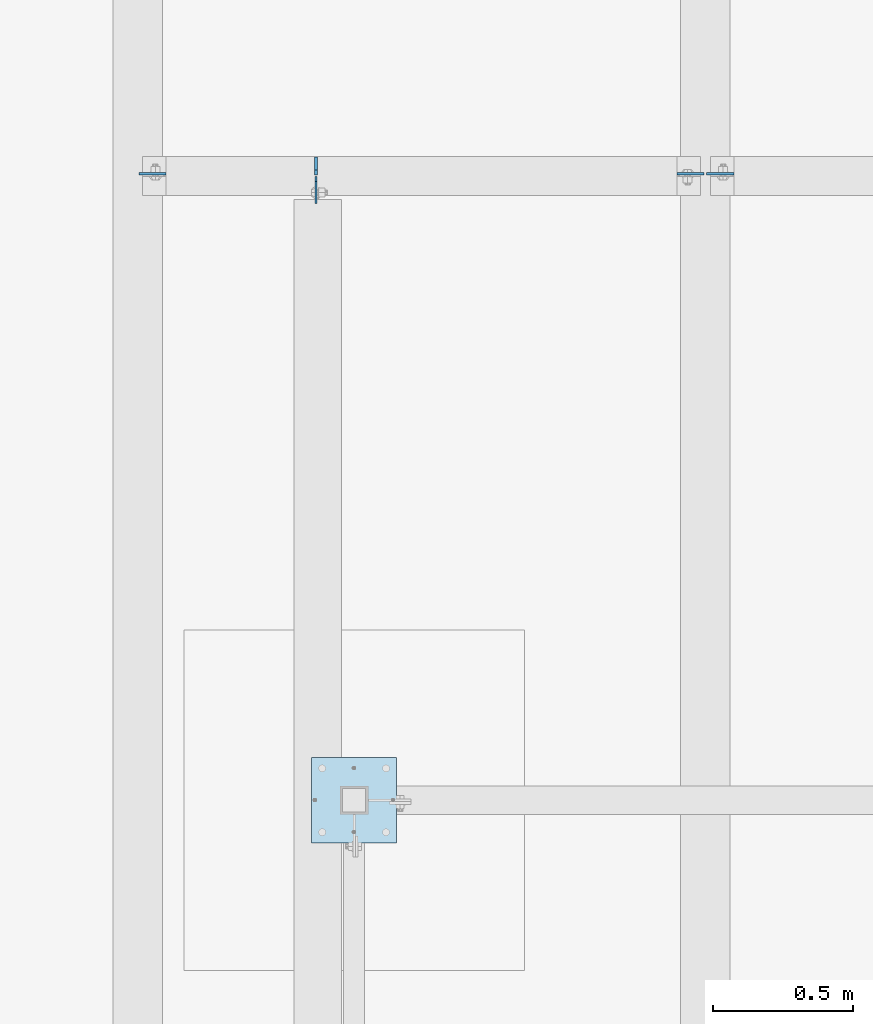
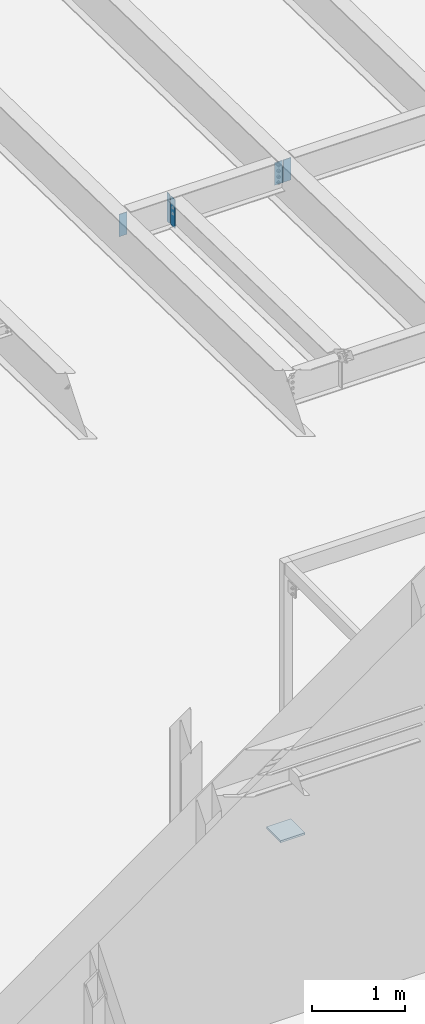
# One storey, part 1471 of 1763: 6 plates, 4 elements without a shape of their own.
"""IFC2X3 building model written with IfcOpenShell, lengths in millimetres."""

from ifc_helpers import new_model, si_unit, frame, origin_with_axes, place, context, subcontext, project, spatial, faceted_brep, material, type_object, element, aggregate, save


model = new_model("IFC2X3")

# Units and contexts
model_context = context("Model", 3, precision=1e-05, world=origin_with_axes())
body_context = subcontext(model_context, "Body", "Model", "MODEL_VIEW")
ifc_project = project(units=[si_unit("LENGTHUNIT", "METRE", prefix="MILLI"), si_unit("AREAUNIT", "SQUARE_METRE"), si_unit("VOLUMEUNIT", "CUBIC_METRE"), si_unit("MASSUNIT", "GRAM", prefix="KILO"), si_unit("TIMEUNIT", "SECOND"), si_unit("PLANEANGLEUNIT", "RADIAN"), si_unit("SOLIDANGLEUNIT", "STERADIAN"), si_unit("THERMODYNAMICTEMPERATUREUNIT", "DEGREE_CELSIUS"), si_unit("LUMINOUSINTENSITYUNIT", "LUMEN")], contexts=[model_context])

# Site, building, storey
site_placement = place(None, origin_with_axes())
site = spatial("IfcSite", under=ifc_project, at=site_placement, CompositionType="ELEMENT")
building_placement = place(site_placement, origin_with_axes())
building = spatial("IfcBuilding", under=site, at=building_placement, Name="Undefined", CompositionType="ELEMENT")
storey_placement = place(building_placement, origin_with_axes())
storey = spatial("IfcBuildingStorey", under=building, at=storey_placement, Name="Undefined", CompositionType="ELEMENT", Elevation=0.0)

# Assembly, plate
assembly_1_placement = place(storey_placement, origin_with_axes())
assembly_1 = element("IfcElementAssembly", 1, at=assembly_1_placement, inside=storey, Name="BEAM", AssemblyPlace="NOTDEFINED", PredefinedType="RIGID_FRAME")
ifc_material = material(Name="STEEL/A36")
plate_type_1 = type_object("IfcPlateType", PredefinedType="NOTDEFINED")
plate_1_placement = place(assembly_1_placement, frame((-58924.2622752818, -8766.2304259654, 11710.6291231283), z_axis=(0.0, 0.0, 1.0), x_axis=(0.0, -1.0, 0.0)))
plate_1 = element("IfcPlate", 2, at=plate_1_placement, type_object=plate_type_1, material=ifc_material, Name="PLATE", context=body_context, shape_type="Brep", body=[
    faceted_brep([(0.0, -3.17500000000291, 17.4624996185303), (0.0, -3.17500000000291, 363.53750038147), (0.0, 3.17500000000291, 363.53750038147), (0.0, 3.17500000000291, 17.4624996185303), (17.4624996185303, -3.17500000000291, 381.0), (17.4624996185303, 3.17500000000291, 381.0), (95.25, -3.17500000000291, 381.0), (95.25, 3.17500000000291, 381.0), (95.25, -3.17500000000291, 0.0), (95.25, 3.17500000000291, 0.0), (17.4624996185303, -3.17500000000291, 0.0), (17.4624996185303, 3.17500000000291, 0.0)], [[[0, 1, 2, 3]], [[1, 4, 5, 2]], [[4, 6, 7, 5]], [[6, 8, 9, 7]], [[8, 10, 11, 9]], [[10, 0, 3, 11]], [[5, 7, 9, 11, 3, 2]], [[10, 8, 6, 4, 1, 0]]]),
])

assembly_2_placement = place(storey_placement, origin_with_axes())
assembly_2 = element("IfcElementAssembly", 3, at=assembly_2_placement, inside=storey, Name="BEAM", AssemblyPlace="NOTDEFINED", PredefinedType="RIGID_FRAME")
plate_type_2 = type_object("IfcPlateType", PredefinedType="NOTDEFINED")
plate_2_placement = place(assembly_2_placement, frame((-57535.1997736983, -8755.91142595737, 12056.7041231251), z_axis=(-1.0, 0.0, 0.0), x_axis=(0.0, 0.0, -1.0)))
plate_2 = element("IfcPlate", 4, at=plate_2_placement, type_object=plate_type_2, material=ifc_material, Name="PLATE", context=body_context, shape_type="Brep", body=[
    faceted_brep([(0.0, -3.96900000000096, 0.0), (0.0, -3.96899999999914, 96.8375015258789), (0.0, 3.96899999999914, 96.8375015258789), (0.0, 3.96900000000096, 0.0), (292.100006103516, -3.96899999999914, 96.8375015258789), (292.100006103516, 3.96899999999914, 96.8375015258789), (292.100006103516, -3.96899999999914, 0.0), (292.100006103516, 3.96899999999914, 0.0)], [[[0, 1, 2, 3]], [[1, 4, 5, 2]], [[4, 6, 7, 5]], [[6, 0, 3, 7]], [[5, 7, 3, 2]], [[6, 4, 1, 0]]]),
])

assembly_3_placement = place(storey_placement, origin_with_axes())
assembly_3 = element("IfcElementAssembly", 5, at=assembly_3_placement, inside=storey, Name="BEAM", AssemblyPlace="NOTDEFINED", PredefinedType="RIGID_FRAME")
plate_3_placement = place(assembly_3_placement, frame((-59557.6747736983, -8755.91142595737, 12056.7041231251), z_axis=(1.0, 0.0, 0.0), x_axis=(0.0, 0.0, -1.0)))
plate_3 = element("IfcPlate", 6, at=plate_3_placement, type_object=plate_type_2, material=ifc_material, Name="PLATE", context=body_context, shape_type="Brep", body=[
    faceted_brep([(0.0, -3.96900000000096, 0.0), (0.0, -3.96899999999914, 96.8375015258789), (0.0, 3.96899999999914, 96.8375015258789), (0.0, 3.96900000000096, 0.0), (292.100006103516, -3.96899999999914, 96.8375015258789), (292.100006103516, 3.96899999999914, 96.8375015258789), (292.100006103516, -3.96899999999914, 0.0), (292.100006103516, 3.96899999999914, 0.0)], [[[0, 1, 2, 3]], [[1, 4, 5, 2]], [[4, 6, 7, 5]], [[6, 0, 3, 7]], [[5, 7, 3, 2]], [[6, 4, 1, 0]]]),
])
aggregate(assembly_3, [plate_3])

# Plate
plate_4_placement = place(assembly_2_placement, frame((-57525.6747736983, -8755.91142595737, 12056.7041231251), z_axis=(1.0, 0.0, 0.0), x_axis=(0.0, 0.0, -1.0)))
plate_4 = element("IfcPlate", 7, at=plate_4_placement, type_object=plate_type_2, material=ifc_material, Name="PLATE", context=body_context, shape_type="Brep", body=[
    faceted_brep([(0.0, -3.96900000000096, 0.0), (0.0, -3.96899999999914, 96.8375015258789), (0.0, 3.96899999999914, 96.8375015258789), (0.0, 3.96900000000096, 0.0), (292.100006103516, -3.96899999999914, 96.8375015258789), (292.100006103516, 3.96899999999914, 96.8375015258789), (292.100006103516, -3.96899999999914, 0.0), (292.100006103516, 3.96899999999914, 0.0)], [[[0, 1, 2, 3]], [[1, 4, 5, 2]], [[4, 6, 7, 5]], [[6, 0, 3, 7]], [[5, 7, 3, 2]], [[6, 4, 1, 0]]]),
])

aggregate(assembly_2, [plate_2, plate_4])

plate_type_3 = type_object("IfcPlateType", PredefinedType="NOTDEFINED")
plate_5_placement = place(assembly_1_placement, frame((-58924.2627751502, -8759.88042596541, 11710.6291231283), z_axis=(0.0, 0.0, 1.0), x_axis=(0.0, 1.0, 0.0)))
plate_5 = element("IfcPlate", 8, at=plate_5_placement, type_object=plate_type_3, material=ifc_material, Name="PLATE", context=body_context, shape_type="Brep", body=[
    faceted_brep([(0.0, -4.76249999999709, 17.4624996185303), (0.0, -4.76249999999709, 363.53750038147), (0.0, 4.76249999999709, 363.53750038147), (0.0, 4.76249999999709, 17.4624996185303), (17.4624996185303, -4.76249999999709, 381.0), (17.4624996185303, 4.76249999999709, 381.0), (63.5, -4.76249999999709, 381.0), (63.5, 4.76249999999709, 381.0), (63.4999999999964, -4.76250000017171, 0.0), (63.5000000000036, 4.76249999982974, 0.0), (17.4624996185303, -4.76249999999709, 0.0), (17.4624996185303, 4.76249999999709, 0.0)], [[[0, 1, 2, 3]], [[1, 4, 5, 2]], [[4, 6, 7, 5]], [[6, 8, 9, 7]], [[8, 10, 11, 9]], [[10, 0, 3, 11]], [[5, 7, 9, 11, 3, 2]], [[10, 8, 6, 4, 1, 0]]]),
])

aggregate(assembly_1, [plate_5, plate_1])

# Assembly, plate
assembly_4_placement = place(storey_placement, origin_with_axes())
assembly_4 = element("IfcElementAssembly", 9, at=assembly_4_placement, inside=storey, Name="COLUMN", AssemblyPlace="NOTDEFINED", PredefinedType="RIGID_FRAME")
plate_type_4 = type_object("IfcPlateType", PredefinedType="NOTDEFINED")
plate_6_placement = place(assembly_4_placement, frame((-58940.1367867304, -10845.8, 5080.0), z_axis=(1.0, 0.0, 0.0), x_axis=(0.0, -1.0, 0.0)))
plate_6 = element("IfcPlate", 10, at=plate_6_placement, type_object=plate_type_4, material=ifc_material, Name="PLATE", context=body_context, shape_type="Brep", body=[
    faceted_brep([(0.0, -12.6999999999971, -1.81898940354586e-12), (0.0, -12.6999999999998, 304.799987792969), (0.0, 12.6999999999998, 304.799987792969), (0.0, 12.6999999999971, -1.81898940354586e-12), (304.799987792969, -12.6999999999998, 304.799987792969), (304.799987792969, 12.6999999999998, 304.799987792969), (304.799987792969, -12.6999999999998, 0.0), (304.799987792969, 12.6999999999998, 0.0)], [[[0, 1, 2, 3]], [[1, 4, 5, 2]], [[4, 6, 7, 5]], [[6, 0, 3, 7]], [[5, 7, 3, 2]], [[6, 4, 1, 0]]]),
])
aggregate(assembly_4, [plate_6])

save(model, "model.ifc")
